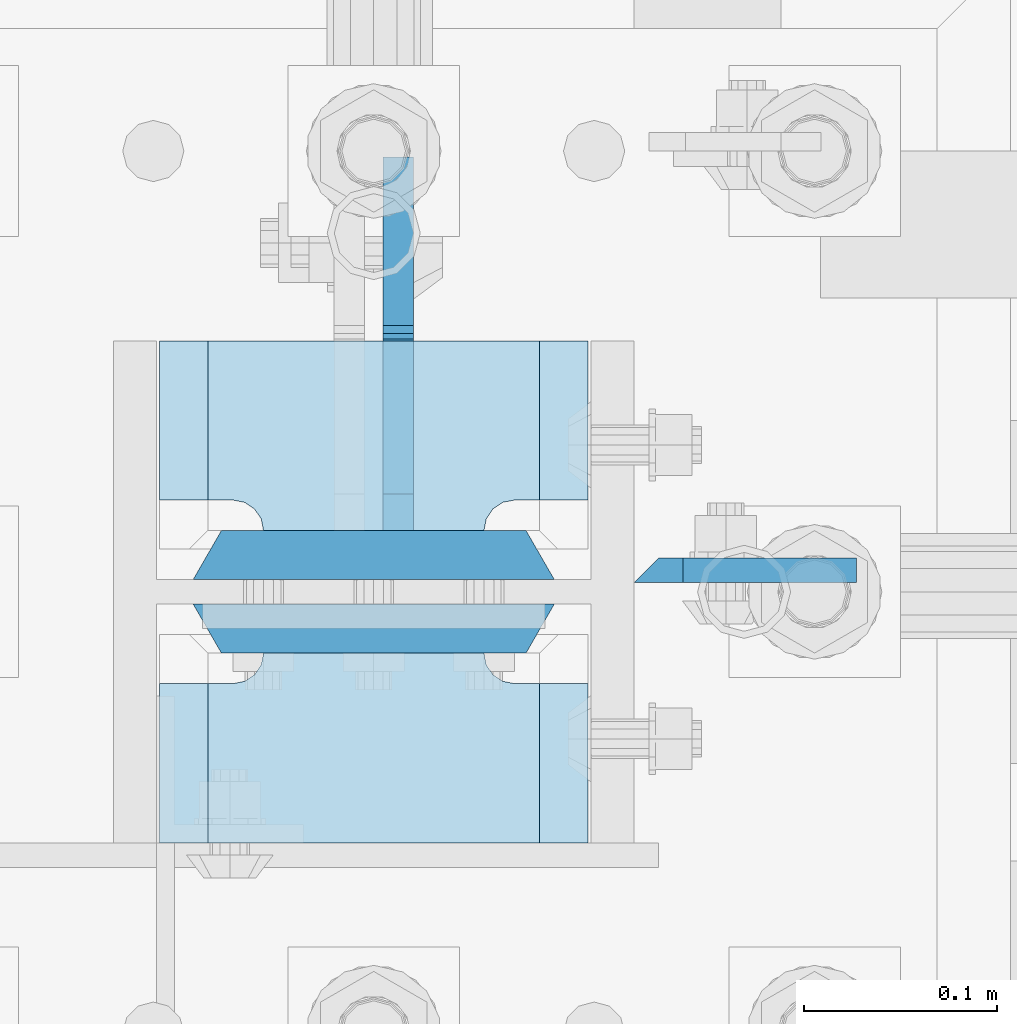
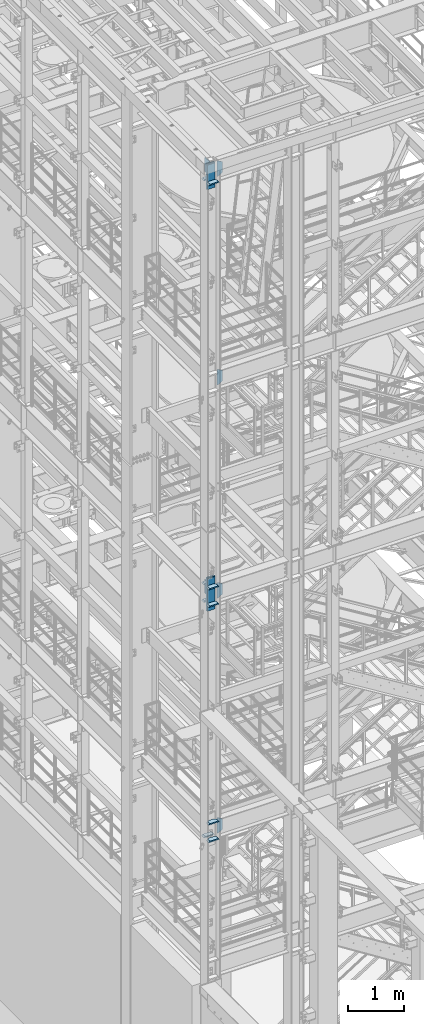
# One storey, part 1421 of 1876: 19 plates, 2 elements without a shape of their own.
"""IFC2X3 building model written with IfcOpenShell, lengths in millimetres."""

from ifc_helpers import new_model, si_unit, frame, origin_with_axes, place, context, subcontext, project, spatial, faceted_brep, material, type_object, element, aggregate, save


model = new_model("IFC2X3")

# Units and contexts
model_context = context("Model", 3, precision=1e-05, world=origin_with_axes())
body_context = subcontext(model_context, "Body", "Model", "MODEL_VIEW")
ifc_project = project(units=[si_unit("LENGTHUNIT", "METRE", prefix="MILLI"), si_unit("AREAUNIT", "SQUARE_METRE"), si_unit("VOLUMEUNIT", "CUBIC_METRE"), si_unit("MASSUNIT", "GRAM", prefix="KILO"), si_unit("TIMEUNIT", "SECOND"), si_unit("PLANEANGLEUNIT", "RADIAN"), si_unit("SOLIDANGLEUNIT", "STERADIAN"), si_unit("THERMODYNAMICTEMPERATUREUNIT", "DEGREE_CELSIUS"), si_unit("LUMINOUSINTENSITYUNIT", "LUMEN")], contexts=[model_context])

# Site, building, storey
site_placement = place(None, origin_with_axes())
site = spatial("IfcSite", under=ifc_project, at=site_placement, CompositionType="ELEMENT")
building_placement = place(site_placement, origin_with_axes())
building = spatial("IfcBuilding", under=site, at=building_placement, Name="Undefined", CompositionType="ELEMENT")
storey_placement = place(building_placement, origin_with_axes())
storey = spatial("IfcBuildingStorey", under=building, at=storey_placement, Name="Undefined", CompositionType="ELEMENT", Elevation=0.0)

# Assembly, plates
assembly_1_placement = place(storey_placement, origin_with_axes())
assembly_1 = element("IfcElementAssembly", 1, at=assembly_1_placement, inside=storey, Name="COLUMN", AssemblyPlace="NOTDEFINED", PredefinedType="RIGID_FRAME")
ifc_material_1 = material(Name="STEEL/A572-50")
plate_type_1 = type_object("IfcPlateType", PredefinedType="NOTDEFINED")
plate_1_placement = place(assembly_1_placement, frame((134.9375, -7100.88799991608, 17946.6875), z_axis=(1.0, 0.0, 0.0), x_axis=(0.0, 0.0, -1.0)))
plate_1 = element("IfcPlate", 2, at=plate_1_placement, type_object=plate_type_1, material=ifc_material_1, Name="PLATE", context=body_context, shape_type="Brep", body=[
    faceted_brep([(0.0, -6.35000000000036, 0.0), (-1.06936913171421e-12, 6.34999999999945, 12.699999332428), (336.549987792969, 6.35000000000036, 12.7), (336.549987792969, -6.35000000000036, 0.0), (336.550000000001, -6.35000000000036, 25.4000000000005), (336.549987792969, 6.35000000000036, 25.4000000000005), (284.53616791736, 6.35000000000036, 115.490600585938), (284.53616791736, -6.35000000000036, 115.490600307004), (52.0138320922852, -6.35000000000036, 115.490599060059), (52.0138320922852, 6.35000000000036, 115.490600585938), (0.0, 6.35000000000036, 25.4000000000005), (0.0, -6.35000000000036, 25.4000000000005)], [[[0, 1, 2, 3]], [[4, 5, 6, 7]], [[8, 9, 10, 11]], [[11, 10, 1, 0]], [[8, 11, 0, 3, 4, 7]], [[9, 8, 7, 6]], [[10, 9, 6, 5, 2, 1]], [[5, 4, 3, 2]]]),
])
plate_2_placement = place(assembly_1_placement, frame((134.9375, -7100.88799991608, 22518.6875), z_axis=(1.0, 0.0, 0.0), x_axis=(0.0, 0.0, -1.0)))
plate_2 = element("IfcPlate", 3, at=plate_2_placement, type_object=plate_type_1, material=ifc_material_1, Name="PLATE", context=body_context, shape_type="Brep", body=[
    faceted_brep([(0.0, -6.35000000000036, 0.0), (-1.06936913171421e-12, 6.34999999999945, 12.699999332428), (336.549987792969, 6.35000000000036, 12.7), (336.549987792969, -6.35000000000036, 0.0), (336.550000000001, -6.35000000000036, 25.4000000000005), (336.549987792969, 6.35000000000036, 25.4000000000005), (284.53616791736, 6.35000000000036, 115.490600585938), (284.53616791736, -6.35000000000036, 115.490600307004), (52.0138320922852, -6.35000000000036, 115.490599060059), (52.0138320922852, 6.35000000000036, 115.490600585938), (0.0, 6.35000000000036, 25.4000000000005), (0.0, -6.35000000000036, 25.4000000000005)], [[[0, 1, 2, 3]], [[4, 5, 6, 7]], [[8, 9, 10, 11]], [[11, 10, 1, 0]], [[8, 11, 0, 3, 4, 7]], [[9, 8, 7, 6]], [[10, 9, 6, 5, 2, 1]], [[5, 4, 3, 2]]]),
])

assembly_2_placement = place(storey_placement, origin_with_axes())
assembly_2 = element("IfcElementAssembly", 4, at=assembly_2_placement, inside=storey, Name="COLUMN", AssemblyPlace="NOTDEFINED", PredefinedType="RIGID_FRAME")
plate_3_placement = place(assembly_2_placement, frame((134.9375, -7100.88799991608, 13273.0875), z_axis=(1.0, 0.0, 0.0), x_axis=(0.0, 0.0, -1.0)))
plate_3 = element("IfcPlate", 5, at=plate_3_placement, type_object=plate_type_1, material=ifc_material_1, Name="PLATE", context=body_context, shape_type="Brep", body=[
    faceted_brep([(0.0, -6.35000000000036, 0.0), (-1.06936913171421e-12, 6.34999999999945, 12.699999332428), (336.549987792969, 6.35000000000036, 12.7), (336.549987792969, -6.35000000000036, 0.0), (336.550000000001, -6.35000000000036, 25.4000000000005), (336.549987792969, 6.35000000000036, 25.4000000000005), (284.53616791736, 6.35000000000036, 115.490600585938), (284.53616791736, -6.35000000000036, 115.490600307004), (52.0138320922852, -6.35000000000036, 115.490599060059), (52.0138320922852, 6.35000000000036, 115.490600585938), (0.0, 6.35000000000036, 25.4000000000005), (0.0, -6.35000000000036, 25.4000000000005)], [[[0, 1, 2, 3]], [[4, 5, 6, 7]], [[8, 9, 10, 11]], [[11, 10, 1, 0]], [[8, 11, 0, 3, 4, 7]], [[9, 8, 7, 6]], [[10, 9, 6, 5, 2, 1]], [[5, 4, 3, 2]]]),
])
plate_4_placement = place(assembly_2_placement, frame((134.9375, -7100.88799991608, 8116.8875), z_axis=(1.0, 0.0, 0.0), x_axis=(0.0, 0.0, -1.0)))
plate_4 = element("IfcPlate", 6, at=plate_4_placement, type_object=plate_type_1, material=ifc_material_1, Name="PLATE", context=body_context, shape_type="Brep", body=[
    faceted_brep([(0.0, -6.35000000000036, 0.0), (-1.06936913171421e-12, 6.34999999999945, 12.699999332428), (336.549987792969, 6.35000000000036, 12.7), (336.549987792969, -6.35000000000036, 0.0), (336.550000000001, -6.35000000000036, 25.4000000000005), (336.549987792969, 6.35000000000036, 25.4000000000005), (284.53616791736, 6.35000000000036, 115.490600585938), (284.53616791736, -6.35000000000036, 115.490600307004), (52.0138320922852, -6.35000000000036, 115.490599060059), (52.0138320922852, 6.35000000000036, 115.490600585938), (0.0, 6.35000000000036, 25.4000000000005), (0.0, -6.35000000000036, 25.4000000000005)], [[[0, 1, 2, 3]], [[4, 5, 6, 7]], [[8, 9, 10, 11]], [[11, 10, 1, 0]], [[8, 11, 0, 3, 4, 7]], [[9, 8, 7, 6]], [[10, 9, 6, 5, 2, 1]], [[5, 4, 3, 2]]]),
])

# Plate
plate_type_2 = type_object("IfcPlateType", PredefinedType="NOTDEFINED")
plate_5_placement = place(assembly_1_placement, frame((111.125, -7143.75, 22158.325012207), z_axis=(-1.0, 0.0, 0.0), x_axis=(0.0, -1.0, 0.0)))
plate_5 = element("IfcPlate", 7, at=plate_5_placement, type_object=plate_type_2, material=ifc_material_1, Name="PLATE", context=body_context, shape_type="Brep", body=[
    faceted_brep([(98.4250030517578, -12.7000000000007, 222.25), (98.4250030517578, 12.7000000000007, 197.150000002177), (15.875, 12.7000000000007, 197.150000002177), (15.875, -12.7000000000007, 222.25), (14.6665875786157, -12.7000000000007, 178.074902037082), (15.875, -12.7000000000007, 184.150001525879), (15.875, 12.7000000000007, 184.150001525879), (14.6665875786157, 12.7000000000007, 178.074902037082), (11.2253201513358, -12.7000000000007, 172.924681374541), (11.2253201513358, 12.7000000000007, 172.924681374541), (6.07509948879488, -12.7000000000007, 169.483413947261), (6.07509948879488, 12.7000000000007, 169.483413947261), (0.0, -12.7000000000007, 168.275001525879), (0.0, 12.7000000000007, 168.275001525879), (0.0, -12.7000000000007, 53.9749984741211), (0.0, 12.7000000000007, 53.9749984741211), (6.07509948879579, -12.7000000000007, 52.7665860527377), (6.07509948879579, 12.7000000000007, 52.7665860527377), (11.2253201513367, -12.7000000000007, 49.3253186254576), (11.2253201513367, 12.7000000000007, 49.3253186254576), (14.6665875786166, -12.7000000000007, 44.1750979629169), (14.6665875786166, 12.7000000000007, 44.1750979629169), (15.875, -12.7000000000007, 38.0999984741211), (15.875, 12.7000000000007, 38.0999984741211), (15.875, 12.7000000000007, 25.0999999978233), (15.875, -12.7000000000007, 0.0), (98.4250030517578, 12.7000000000007, 25.0999999978233), (98.4250030517578, -12.7000000000007, 0.0)], [[[0, 1, 2, 3]], [[4, 5, 6, 7]], [[8, 4, 7, 9]], [[10, 8, 9, 11]], [[12, 10, 11, 13]], [[14, 12, 13, 15]], [[16, 14, 15, 17]], [[18, 16, 17, 19]], [[20, 18, 19, 21]], [[22, 20, 21, 23]], [[22, 23, 24, 25]], [[26, 27, 25, 24]], [[5, 4, 8, 10, 12, 14, 16, 18, 20, 22, 25, 27, 0, 3]], [[6, 5, 3, 2]], [[26, 24, 23, 21, 19, 17, 15, 13, 11, 9, 7, 6, 2, 1]], [[27, 26, 1, 0]]]),
])

plate_6_placement = place(assembly_1_placement, frame((111.125, -6981.825, 22158.325012207), z_axis=(-1.0, 0.0, 0.0), x_axis=(0.0, -1.0, 0.0)))
plate_6 = element("IfcPlate", 8, at=plate_6_placement, type_object=plate_type_2, material=ifc_material_1, Name="PLATE", context=body_context, shape_type="Brep", body=[
    faceted_brep([(82.5500030517578, -12.7000000000007, 222.25), (82.5500030517578, 12.7000000000007, 197.150000002177), (0.0, 12.7000000000007, 197.150000002177), (0.0, -12.7000000000007, 222.25), (82.5500030517578, 12.7000000000007, 25.0999999978233), (82.5500030517578, -12.7000000000007, 0.0), (0.0, -12.6999999999998, 0.0), (0.0, 12.7000000000007, 25.0999999978233), (82.5500030517578, 12.7000000000007, 38.0999984741211), (82.5500030517578, -12.7000000000007, 38.0999984741211), (83.7584154731412, -12.7000000000007, 44.1750979629169), (83.7584154731412, 12.7000000000007, 44.1750979629169), (87.1996829004211, -12.7000000000007, 49.3253186254576), (87.1996829004211, 12.7000000000007, 49.3253186254576), (92.349903562962, -12.7000000000007, 52.7665860527377), (92.349903562962, 12.7000000000007, 52.7665860527377), (98.4250030517578, -12.7000000000007, 53.9749984741211), (98.4250030517578, 12.7000000000007, 53.9749984741211), (98.4250030517578, -12.7000000000007, 168.275001525879), (98.4250030517578, 12.7000000000007, 168.275001525879), (92.349903562962, -12.7000000000007, 169.483413947262), (92.349903562962, 12.7000000000007, 169.483413947262), (87.1996829004211, -12.7000000000007, 172.924681374543), (87.1996829004211, 12.7000000000007, 172.924681374543), (83.7584154731412, -12.7000000000007, 178.074902037083), (83.7584154731412, 12.7000000000007, 178.074902037083), (82.5500030517578, -12.7000000000007, 184.150001525879), (82.5500030517578, 12.7000000000007, 184.150001525879)], [[[0, 1, 2, 3]], [[4, 5, 6, 7]], [[8, 9, 5, 4]], [[10, 9, 8, 11]], [[12, 10, 11, 13]], [[14, 12, 13, 15]], [[16, 14, 15, 17]], [[18, 16, 17, 19]], [[20, 18, 19, 21]], [[22, 20, 21, 23]], [[24, 22, 23, 25]], [[26, 24, 25, 27]], [[6, 5, 9, 10, 12, 14, 16, 18, 20, 22, 24, 26, 0, 3]], [[7, 6, 3, 2]], [[27, 25, 23, 21, 19, 17, 15, 13, 11, 8, 4, 7, 2, 1]], [[26, 27, 1, 0]]]),
])

plate_7_placement = place(assembly_2_placement, frame((111.125, -7143.75, 12912.725012207), z_axis=(-1.0, 0.0, 0.0), x_axis=(0.0, -1.0, 0.0)))
plate_7 = element("IfcPlate", 9, at=plate_7_placement, type_object=plate_type_2, material=ifc_material_1, Name="PLATE", context=body_context, shape_type="Brep", body=[
    faceted_brep([(98.4250030517578, -12.7000000000007, 222.25), (98.4250030517578, 12.7000000000007, 197.150000002177), (15.875, 12.7000000000007, 197.150000002177), (15.875, -12.7000000000007, 222.25), (14.6665875786157, -12.7000000000007, 178.074902037082), (15.875, -12.7000000000007, 184.150001525879), (15.875, 12.7000000000007, 184.150001525879), (14.6665875786157, 12.7000000000007, 178.074902037082), (11.2253201513358, -12.7000000000007, 172.924681374541), (11.2253201513358, 12.7000000000007, 172.924681374541), (6.07509948879488, -12.7000000000007, 169.483413947261), (6.07509948879488, 12.7000000000007, 169.483413947261), (0.0, -12.7000000000007, 168.275001525879), (0.0, 12.7000000000007, 168.275001525879), (0.0, -12.7000000000007, 53.9749984741211), (0.0, 12.7000000000007, 53.9749984741211), (6.07509948879579, -12.7000000000007, 52.7665860527377), (6.07509948879579, 12.7000000000007, 52.7665860527377), (11.2253201513367, -12.7000000000007, 49.3253186254576), (11.2253201513367, 12.7000000000007, 49.3253186254576), (14.6665875786166, -12.7000000000007, 44.1750979629169), (14.6665875786166, 12.7000000000007, 44.1750979629169), (15.875, -12.7000000000007, 38.0999984741211), (15.875, 12.7000000000007, 38.0999984741211), (15.875, 12.7000000000007, 25.0999999978233), (15.875, -12.7000000000007, 0.0), (98.4250030517578, 12.7000000000007, 25.0999999978233), (98.4250030517578, -12.7000000000007, 0.0)], [[[0, 1, 2, 3]], [[4, 5, 6, 7]], [[8, 4, 7, 9]], [[10, 8, 9, 11]], [[12, 10, 11, 13]], [[14, 12, 13, 15]], [[16, 14, 15, 17]], [[18, 16, 17, 19]], [[20, 18, 19, 21]], [[22, 20, 21, 23]], [[22, 23, 24, 25]], [[26, 27, 25, 24]], [[5, 4, 8, 10, 12, 14, 16, 18, 20, 22, 25, 27, 0, 3]], [[6, 5, 3, 2]], [[26, 24, 23, 21, 19, 17, 15, 13, 11, 9, 7, 6, 2, 1]], [[27, 26, 1, 0]]]),
])

plate_8_placement = place(assembly_2_placement, frame((111.125, -7143.75, 13296.9), z_axis=(-1.0, 0.0, 0.0), x_axis=(0.0, -1.0, 0.0)))
plate_8 = element("IfcPlate", 10, at=plate_8_placement, type_object=plate_type_2, material=ifc_material_1, Name="PLATE", context=body_context, shape_type="Brep", body=[
    faceted_brep([(98.4250030517578, -12.7000000000007, 222.25), (98.4250030517578, 12.7000000000007, 197.150000002177), (15.875, 12.7000000000007, 197.150000002177), (15.875, -12.7000000000007, 222.25), (14.6665875786157, -12.7000000000007, 178.074902037082), (15.875, -12.7000000000007, 184.150001525879), (15.875, 12.7000000000007, 184.150001525879), (14.6665875786157, 12.7000000000007, 178.074902037082), (11.2253201513358, -12.7000000000007, 172.924681374541), (11.2253201513358, 12.7000000000007, 172.924681374541), (6.07509948879488, -12.7000000000007, 169.483413947261), (6.07509948879488, 12.7000000000007, 169.483413947261), (0.0, -12.7000000000007, 168.275001525879), (0.0, 12.7000000000007, 168.275001525879), (0.0, -12.7000000000007, 53.9749984741211), (0.0, 12.7000000000007, 53.9749984741211), (6.07509948879579, -12.7000000000007, 52.7665860527377), (6.07509948879579, 12.7000000000007, 52.7665860527377), (11.2253201513367, -12.7000000000007, 49.3253186254576), (11.2253201513367, 12.7000000000007, 49.3253186254576), (14.6665875786166, -12.7000000000007, 44.1750979629169), (14.6665875786166, 12.7000000000007, 44.1750979629169), (15.875, -12.7000000000007, 38.0999984741211), (15.875, 12.7000000000007, 38.0999984741211), (15.875, 12.7000000000007, 25.0999999978233), (15.875, -12.7000000000007, 0.0), (98.4250030517578, 12.7000000000007, 25.0999999978233), (98.4250030517578, -12.7000000000007, 0.0)], [[[0, 1, 2, 3]], [[4, 5, 6, 7]], [[8, 4, 7, 9]], [[10, 8, 9, 11]], [[12, 10, 11, 13]], [[14, 12, 13, 15]], [[16, 14, 15, 17]], [[18, 16, 17, 19]], [[20, 18, 19, 21]], [[22, 20, 21, 23]], [[22, 23, 24, 25]], [[26, 27, 25, 24]], [[5, 4, 8, 10, 12, 14, 16, 18, 20, 22, 25, 27, 0, 3]], [[6, 5, 3, 2]], [[26, 24, 23, 21, 19, 17, 15, 13, 11, 9, 7, 6, 2, 1]], [[27, 26, 1, 0]]]),
])

plate_9_placement = place(assembly_2_placement, frame((111.125, -6981.825, 12912.725012207), z_axis=(-1.0, 0.0, 0.0), x_axis=(0.0, -1.0, 0.0)))
plate_9 = element("IfcPlate", 11, at=plate_9_placement, type_object=plate_type_2, material=ifc_material_1, Name="PLATE", context=body_context, shape_type="Brep", body=[
    faceted_brep([(82.5500030517578, -12.7000000000007, 222.25), (82.5500030517578, 12.7000000000007, 197.150000002177), (0.0, 12.7000000000007, 197.150000002177), (0.0, -12.7000000000007, 222.25), (82.5500030517578, 12.7000000000007, 25.0999999978233), (82.5500030517578, -12.7000000000007, 0.0), (0.0, -12.6999999999998, 0.0), (0.0, 12.7000000000007, 25.0999999978233), (82.5500030517578, 12.7000000000007, 38.0999984741211), (82.5500030517578, -12.7000000000007, 38.0999984741211), (83.7584154731412, -12.7000000000007, 44.1750979629169), (83.7584154731412, 12.7000000000007, 44.1750979629169), (87.1996829004211, -12.7000000000007, 49.3253186254576), (87.1996829004211, 12.7000000000007, 49.3253186254576), (92.349903562962, -12.7000000000007, 52.7665860527377), (92.349903562962, 12.7000000000007, 52.7665860527377), (98.4250030517578, -12.7000000000007, 53.9749984741211), (98.4250030517578, 12.7000000000007, 53.9749984741211), (98.4250030517578, -12.7000000000007, 168.275001525879), (98.4250030517578, 12.7000000000007, 168.275001525879), (92.349903562962, -12.7000000000007, 169.483413947262), (92.349903562962, 12.7000000000007, 169.483413947262), (87.1996829004211, -12.7000000000007, 172.924681374543), (87.1996829004211, 12.7000000000007, 172.924681374543), (83.7584154731412, -12.7000000000007, 178.074902037083), (83.7584154731412, 12.7000000000007, 178.074902037083), (82.5500030517578, -12.7000000000007, 184.150001525879), (82.5500030517578, 12.7000000000007, 184.150001525879)], [[[0, 1, 2, 3]], [[4, 5, 6, 7]], [[8, 9, 5, 4]], [[10, 9, 8, 11]], [[12, 10, 11, 13]], [[14, 12, 13, 15]], [[16, 14, 15, 17]], [[18, 16, 17, 19]], [[20, 18, 19, 21]], [[22, 20, 21, 23]], [[24, 22, 23, 25]], [[26, 24, 25, 27]], [[6, 5, 9, 10, 12, 14, 16, 18, 20, 22, 24, 26, 0, 3]], [[7, 6, 3, 2]], [[27, 25, 23, 21, 19, 17, 15, 13, 11, 8, 4, 7, 2, 1]], [[26, 27, 1, 0]]]),
])

plate_10_placement = place(assembly_2_placement, frame((111.125, -6981.825, 13296.9), z_axis=(-1.0, 0.0, 0.0), x_axis=(0.0, -1.0, 0.0)))
plate_10 = element("IfcPlate", 12, at=plate_10_placement, type_object=plate_type_2, material=ifc_material_1, Name="PLATE", context=body_context, shape_type="Brep", body=[
    faceted_brep([(82.5500030517578, -12.7000000000007, 222.25), (82.5500030517578, 12.7000000000007, 197.150000002177), (0.0, 12.7000000000007, 197.150000002177), (0.0, -12.7000000000007, 222.25), (82.5500030517578, 12.7000000000007, 25.0999999978233), (82.5500030517578, -12.7000000000007, 0.0), (0.0, -12.6999999999998, 0.0), (0.0, 12.7000000000007, 25.0999999978233), (82.5500030517578, 12.7000000000007, 38.0999984741211), (82.5500030517578, -12.7000000000007, 38.0999984741211), (83.7584154731412, -12.7000000000007, 44.1750979629169), (83.7584154731412, 12.7000000000007, 44.1750979629169), (87.1996829004211, -12.7000000000007, 49.3253186254576), (87.1996829004211, 12.7000000000007, 49.3253186254576), (92.349903562962, -12.7000000000007, 52.7665860527377), (92.349903562962, 12.7000000000007, 52.7665860527377), (98.4250030517578, -12.7000000000007, 53.9749984741211), (98.4250030517578, 12.7000000000007, 53.9749984741211), (98.4250030517578, -12.7000000000007, 168.275001525879), (98.4250030517578, 12.7000000000007, 168.275001525879), (92.349903562962, -12.7000000000007, 169.483413947262), (92.349903562962, 12.7000000000007, 169.483413947262), (87.1996829004211, -12.7000000000007, 172.924681374543), (87.1996829004211, 12.7000000000007, 172.924681374543), (83.7584154731412, -12.7000000000007, 178.074902037083), (83.7584154731412, 12.7000000000007, 178.074902037083), (82.5500030517578, -12.7000000000007, 184.150001525879), (82.5500030517578, 12.7000000000007, 184.150001525879)], [[[0, 1, 2, 3]], [[4, 5, 6, 7]], [[8, 9, 5, 4]], [[10, 9, 8, 11]], [[12, 10, 11, 13]], [[14, 12, 13, 15]], [[16, 14, 15, 17]], [[18, 16, 17, 19]], [[20, 18, 19, 21]], [[22, 20, 21, 23]], [[24, 22, 23, 25]], [[26, 24, 25, 27]], [[6, 5, 9, 10, 12, 14, 16, 18, 20, 22, 24, 26, 0, 3]], [[7, 6, 3, 2]], [[27, 25, 23, 21, 19, 17, 15, 13, 11, 8, 4, 7, 2, 1]], [[26, 27, 1, 0]]]),
])

plate_11_placement = place(assembly_2_placement, frame((111.125, -7143.75, 7756.52501220703), z_axis=(-1.0, 0.0, 0.0), x_axis=(0.0, -1.0, 0.0)))
plate_11 = element("IfcPlate", 13, at=plate_11_placement, type_object=plate_type_2, material=ifc_material_1, Name="PLATE", context=body_context, shape_type="Brep", body=[
    faceted_brep([(98.4250030517578, -12.7000000000007, 222.25), (98.4250030517578, 12.7000000000007, 197.150000002177), (15.875, 12.7000000000007, 197.150000002177), (15.875, -12.7000000000007, 222.25), (14.6665875786157, -12.7000000000007, 178.074902037082), (15.875, -12.7000000000007, 184.150001525879), (15.875, 12.7000000000007, 184.150001525879), (14.6665875786157, 12.7000000000007, 178.074902037082), (11.2253201513358, -12.7000000000007, 172.924681374541), (11.2253201513358, 12.7000000000007, 172.924681374541), (6.07509948879488, -12.7000000000007, 169.483413947261), (6.07509948879488, 12.7000000000007, 169.483413947261), (0.0, -12.7000000000007, 168.275001525879), (0.0, 12.7000000000007, 168.275001525879), (0.0, -12.7000000000007, 53.9749984741211), (0.0, 12.7000000000007, 53.9749984741211), (6.07509948879579, -12.7000000000007, 52.7665860527377), (6.07509948879579, 12.7000000000007, 52.7665860527377), (11.2253201513367, -12.7000000000007, 49.3253186254576), (11.2253201513367, 12.7000000000007, 49.3253186254576), (14.6665875786166, -12.7000000000007, 44.1750979629169), (14.6665875786166, 12.7000000000007, 44.1750979629169), (15.875, -12.7000000000007, 38.0999984741211), (15.875, 12.7000000000007, 38.0999984741211), (15.875, 12.7000000000007, 25.0999999978233), (15.875, -12.7000000000007, 0.0), (98.4250030517578, 12.7000000000007, 25.0999999978233), (98.4250030517578, -12.7000000000007, 0.0)], [[[0, 1, 2, 3]], [[4, 5, 6, 7]], [[8, 4, 7, 9]], [[10, 8, 9, 11]], [[12, 10, 11, 13]], [[14, 12, 13, 15]], [[16, 14, 15, 17]], [[18, 16, 17, 19]], [[20, 18, 19, 21]], [[22, 20, 21, 23]], [[22, 23, 24, 25]], [[26, 27, 25, 24]], [[5, 4, 8, 10, 12, 14, 16, 18, 20, 22, 25, 27, 0, 3]], [[6, 5, 3, 2]], [[26, 24, 23, 21, 19, 17, 15, 13, 11, 9, 7, 6, 2, 1]], [[27, 26, 1, 0]]]),
])

plate_12_placement = place(assembly_2_placement, frame((111.125, -7143.75, 8140.7), z_axis=(-1.0, 0.0, 0.0), x_axis=(0.0, -1.0, 0.0)))
plate_12 = element("IfcPlate", 14, at=plate_12_placement, type_object=plate_type_2, material=ifc_material_1, Name="PLATE", context=body_context, shape_type="Brep", body=[
    faceted_brep([(98.4250030517578, -12.7000000000007, 222.25), (98.4250030517578, 12.7000000000007, 197.150000002177), (15.875, 12.7000000000007, 197.150000002177), (15.875, -12.7000000000007, 222.25), (14.6665875786157, -12.7000000000007, 178.074902037082), (15.875, -12.7000000000007, 184.150001525879), (15.875, 12.7000000000007, 184.150001525879), (14.6665875786157, 12.7000000000007, 178.074902037082), (11.2253201513358, -12.7000000000007, 172.924681374541), (11.2253201513358, 12.7000000000007, 172.924681374541), (6.07509948879488, -12.7000000000007, 169.483413947261), (6.07509948879488, 12.7000000000007, 169.483413947261), (0.0, -12.7000000000007, 168.275001525879), (0.0, 12.7000000000007, 168.275001525879), (0.0, -12.7000000000007, 53.9749984741211), (0.0, 12.7000000000007, 53.9749984741211), (6.07509948879579, -12.7000000000007, 52.7665860527377), (6.07509948879579, 12.7000000000007, 52.7665860527377), (11.2253201513367, -12.7000000000007, 49.3253186254576), (11.2253201513367, 12.7000000000007, 49.3253186254576), (14.6665875786166, -12.7000000000007, 44.1750979629169), (14.6665875786166, 12.7000000000007, 44.1750979629169), (15.875, -12.7000000000007, 38.0999984741211), (15.875, 12.7000000000007, 38.0999984741211), (15.875, 12.7000000000007, 25.0999999978233), (15.875, -12.7000000000007, 0.0), (98.4250030517578, 12.7000000000007, 25.0999999978233), (98.4250030517578, -12.7000000000007, 0.0)], [[[0, 1, 2, 3]], [[4, 5, 6, 7]], [[8, 4, 7, 9]], [[10, 8, 9, 11]], [[12, 10, 11, 13]], [[14, 12, 13, 15]], [[16, 14, 15, 17]], [[18, 16, 17, 19]], [[20, 18, 19, 21]], [[22, 20, 21, 23]], [[22, 23, 24, 25]], [[26, 27, 25, 24]], [[5, 4, 8, 10, 12, 14, 16, 18, 20, 22, 25, 27, 0, 3]], [[6, 5, 3, 2]], [[26, 24, 23, 21, 19, 17, 15, 13, 11, 9, 7, 6, 2, 1]], [[27, 26, 1, 0]]]),
])

plate_13_placement = place(assembly_2_placement, frame((111.125, -6981.825, 7756.52501220703), z_axis=(-1.0, 0.0, 0.0), x_axis=(0.0, -1.0, 0.0)))
plate_13 = element("IfcPlate", 15, at=plate_13_placement, type_object=plate_type_2, material=ifc_material_1, Name="PLATE", context=body_context, shape_type="Brep", body=[
    faceted_brep([(82.5500030517578, -12.7000000000007, 222.25), (82.5500030517578, 12.7000000000007, 197.150000002177), (0.0, 12.7000000000007, 197.150000002177), (0.0, -12.7000000000007, 222.25), (82.5500030517578, 12.7000000000007, 25.0999999978233), (82.5500030517578, -12.7000000000007, 0.0), (0.0, -12.6999999999998, 0.0), (0.0, 12.7000000000007, 25.0999999978233), (82.5500030517578, 12.7000000000007, 38.0999984741211), (82.5500030517578, -12.7000000000007, 38.0999984741211), (83.7584154731412, -12.7000000000007, 44.1750979629169), (83.7584154731412, 12.7000000000007, 44.1750979629169), (87.1996829004211, -12.7000000000007, 49.3253186254576), (87.1996829004211, 12.7000000000007, 49.3253186254576), (92.349903562962, -12.7000000000007, 52.7665860527377), (92.349903562962, 12.7000000000007, 52.7665860527377), (98.4250030517578, -12.7000000000007, 53.9749984741211), (98.4250030517578, 12.7000000000007, 53.9749984741211), (98.4250030517578, -12.7000000000007, 168.275001525879), (98.4250030517578, 12.7000000000007, 168.275001525879), (92.349903562962, -12.7000000000007, 169.483413947262), (92.349903562962, 12.7000000000007, 169.483413947262), (87.1996829004211, -12.7000000000007, 172.924681374543), (87.1996829004211, 12.7000000000007, 172.924681374543), (83.7584154731412, -12.7000000000007, 178.074902037083), (83.7584154731412, 12.7000000000007, 178.074902037083), (82.5500030517578, -12.7000000000007, 184.150001525879), (82.5500030517578, 12.7000000000007, 184.150001525879)], [[[0, 1, 2, 3]], [[4, 5, 6, 7]], [[8, 9, 5, 4]], [[10, 9, 8, 11]], [[12, 10, 11, 13]], [[14, 12, 13, 15]], [[16, 14, 15, 17]], [[18, 16, 17, 19]], [[20, 18, 19, 21]], [[22, 20, 21, 23]], [[24, 22, 23, 25]], [[26, 24, 25, 27]], [[6, 5, 9, 10, 12, 14, 16, 18, 20, 22, 24, 26, 0, 3]], [[7, 6, 3, 2]], [[27, 25, 23, 21, 19, 17, 15, 13, 11, 8, 4, 7, 2, 1]], [[26, 27, 1, 0]]]),
])

ifc_material_2 = material(Name="STEEL/A572-GR.50")
plate_type_3 = type_object("IfcPlateType", PredefinedType="NOTDEFINED")
plate_14_placement = place(assembly_1_placement, frame((-93.6625, -7092.95, 22529.8), z_axis=(1.0, 0.0, 0.0), x_axis=(0.0, 0.0, -1.0)))
plate_14 = element("IfcPlate", 16, at=plate_14_placement, type_object=plate_type_3, material=ifc_material_2, Name="PLATE", context=body_context, shape_type="Brep", body=[
    faceted_brep([(0.0, 12.6999999999998, 172.66030316161), (0.0, -12.6999999999998, 187.324996948242), (536.575012207031, -12.6999999999998, 187.324996948242), (536.575012207031, 12.6999999999998, 172.66030316161), (536.575012207031, 12.6999999999998, 14.6646968383725), (0.0, 12.6999999999998, 14.6646968383725), (0.0, -12.6999999999998, 0.0), (536.575012207031, -12.6999999999998, 0.0)], [[[0, 1, 2, 3]], [[0, 3, 4, 5]], [[1, 0, 5, 6]], [[2, 1, 6, 7]], [[3, 2, 7, 4]], [[6, 5, 4, 7]]]),
])

plate_15_placement = place(assembly_1_placement, frame((-93.6625, -7131.05, 22529.8), z_axis=(1.0, 0.0, 0.0), x_axis=(0.0, 0.0, -1.0)))
plate_15 = element("IfcPlate", 17, at=plate_15_placement, type_object=plate_type_3, material=ifc_material_2, Name="PLATE", context=body_context, shape_type="Brep", body=[
    faceted_brep([(0.0, -12.6999999999998, 172.660303166218), (536.575012207031, -12.6999999999998, 172.660303166218), (536.575012207031, 12.6999999999998, 187.324996948242), (0.0, 12.6999999999998, 187.324996948242), (536.575012207031, -12.6999999999998, 14.6646968337648), (536.575012207031, 12.6999999999998, 0.0), (0.0, 12.6999999999998, 0.0), (0.0, -12.6999999999998, 14.6646968337648)], [[[0, 1, 2, 3]], [[2, 1, 4, 5]], [[3, 2, 5, 6]], [[0, 3, 6, 7]], [[1, 0, 7, 4]], [[6, 5, 4, 7]]]),
])

plate_16_placement = place(assembly_2_placement, frame((-93.6625, -7131.05, 13462.0), z_axis=(1.0, 0.0, 0.0), x_axis=(0.0, 0.0, -1.0)))
plate_16 = element("IfcPlate", 18, at=plate_16_placement, type_object=plate_type_3, material=ifc_material_2, Name="PLATE", context=body_context, shape_type="Brep", body=[
    faceted_brep([(0.0, -12.6999999999998, 172.660303166218), (714.375, -12.6999999999998, 172.660303166232), (714.375, 12.6999999999998, 187.324996948242), (0.0, 12.6999999999998, 187.324996948242), (714.375, -12.6999999999998, 14.6646968337647), (714.375, 12.6999999999998, 0.0), (0.0, 12.6999999999998, 0.0), (0.0, -12.6999999999998, 14.6646968337648)], [[[0, 1, 2, 3]], [[2, 1, 4, 5]], [[3, 2, 5, 6]], [[0, 3, 6, 7]], [[1, 0, 7, 4]], [[6, 5, 4, 7]]]),
])

plate_17_placement = place(assembly_2_placement, frame((-93.6625, -7092.95, 13462.0), z_axis=(1.0, 0.0, 0.0), x_axis=(0.0, 0.0, -1.0)))
plate_17 = element("IfcPlate", 19, at=plate_17_placement, type_object=plate_type_3, material=ifc_material_2, Name="PLATE", context=body_context, shape_type="Brep", body=[
    faceted_brep([(0.0, 12.6999999999998, 172.66030316161), (0.0, -12.6999999999998, 187.324996948242), (714.375, -12.6999999999998, 187.324996948242), (714.375, 12.6999999999998, 172.660303161603), (714.375, 12.6999999999998, 14.6646968384017), (0.0, 12.6999999999998, 14.6646968383725), (0.0, -12.6999999999998, 0.0), (714.375, -12.6999999999998, 0.0)], [[[0, 1, 2, 3]], [[0, 3, 4, 5]], [[1, 0, 5, 6]], [[2, 1, 6, 7]], [[3, 2, 7, 4]], [[6, 5, 4, 7]]]),
])

plate_type_4 = type_object("IfcPlateType", PredefinedType="NOTDEFINED")
plate_18_placement = place(assembly_1_placement, frame((12.6995000839233, -7080.25, 22529.8), z_axis=(0.0, 1.0, 0.0), x_axis=(0.0, 0.0, -1.0)))
plate_18 = element("IfcPlate", 20, at=plate_18_placement, type_object=plate_type_4, material=ifc_material_1, Name="PLATE", context=body_context, shape_type="Brep", body=[
    faceted_brep([(317.499987030027, -7.9375, 193.675002687786), (317.499987030027, -7.9375, 111.124999809264), (317.499987030027, 7.9375, 111.124999809264), (317.499987030027, 7.9375, 193.675003051758), (318.466716952618, -7.9375, 106.264920291219), (318.466716952618, 7.9375, 106.264920291219), (321.219730853096, -7.9375, 102.144743823065), (321.219730853096, 7.9375, 102.144743823065), (325.339907321249, -7.9375, 99.3917299225868), (325.339907321249, 7.9375, 99.3917299225868), (330.199986839292, -7.9375, 98.4249999999993), (330.199986839292, 7.9375, 98.4249999999993), (358.774999999998, -7.9375, 98.4249999999993), (358.774993896484, 7.9375, 98.4249999999993), (12.7000000839216, -7.9375, 193.674999999999), (12.7000000839216, 7.9375, 193.675003051758), (12.7000000839216, 7.9375, 111.124999809264), (12.7000000839216, -7.9375, 111.124999809264), (11.7332701613341, 7.9375, 106.264920291219), (11.7332701613341, -7.9375, 106.264920291219), (8.98025626085655, 7.9375, 102.144743823065), (8.98025626085655, -7.9375, 102.144743823065), (4.86007979270289, 7.9375, 99.3917299225868), (4.86007979270289, -7.9375, 99.3917299225868), (0.0, 7.9375, 98.4249999999993), (0.0, -7.9375, 98.4249999999993), (0.0, 7.9375, 19.0499992370605), (0.0, -7.9375, 19.0499992370605), (19.0499992370605, -7.9375, 0.0), (19.0499992370605, 7.9375, 0.0), (339.724994659424, -7.9375, 0.0), (339.724994659424, 7.9375, 0.0), (358.774993896484, -7.9375, 19.0499992370605), (358.774993896484, 7.9375, 19.0499992370605)], [[[0, 1, 2, 3]], [[4, 5, 2, 1]], [[6, 7, 5, 4]], [[8, 9, 7, 6]], [[10, 11, 9, 8]], [[12, 13, 11, 10]], [[14, 15, 16, 17]], [[17, 16, 18, 19]], [[19, 18, 20, 21]], [[21, 20, 22, 23]], [[23, 22, 24, 25]], [[26, 27, 25, 24]], [[28, 27, 26, 29]], [[30, 28, 29, 31]], [[32, 30, 31, 33]], [[8, 6, 4, 1, 0, 14, 17, 19, 21, 23, 25, 27, 28, 30, 32, 12, 10]], [[15, 14, 0, 3]], [[33, 31, 29, 26, 24, 22, 20, 18, 16, 15, 3, 2, 5, 7, 9, 11, 13]], [[32, 33, 13, 12]]]),
])

aggregate(assembly_1, [plate_1, plate_2, plate_5, plate_6, plate_18, plate_14, plate_15])

plate_19_placement = place(assembly_2_placement, frame((12.6995000839233, -7080.25, 13284.2), z_axis=(0.0, 1.0, 0.0), x_axis=(0.0, 0.0, -1.0)))
plate_19 = element("IfcPlate", 21, at=plate_19_placement, type_object=plate_type_4, material=ifc_material_1, Name="PLATE", context=body_context, shape_type="Brep", body=[
    faceted_brep([(317.499987030027, -7.9375, 193.675002687786), (317.499987030027, -7.9375, 111.124999809264), (317.499987030027, 7.9375, 111.124999809264), (317.499987030027, 7.9375, 193.675003051758), (318.466716952618, -7.9375, 106.264920291219), (318.466716952618, 7.9375, 106.264920291219), (321.219730853096, -7.9375, 102.144743823065), (321.219730853096, 7.9375, 102.144743823065), (325.339907321249, -7.9375, 99.3917299225868), (325.339907321249, 7.9375, 99.3917299225868), (330.199986839292, -7.9375, 98.4249999999993), (330.199986839292, 7.9375, 98.4249999999993), (358.774999999998, -7.9375, 98.4249999999993), (358.774993896484, 7.9375, 98.4249999999993), (12.7000000839216, -7.9375, 193.674999999999), (12.7000000839216, 7.9375, 193.675003051758), (12.7000000839216, 7.9375, 111.124999809264), (12.7000000839216, -7.9375, 111.124999809264), (11.7332701613341, 7.9375, 106.264920291219), (11.7332701613341, -7.9375, 106.264920291219), (8.98025626085655, 7.9375, 102.144743823065), (8.98025626085655, -7.9375, 102.144743823065), (4.86007979270289, 7.9375, 99.3917299225868), (4.86007979270289, -7.9375, 99.3917299225868), (0.0, 7.9375, 98.4249999999993), (0.0, -7.9375, 98.4249999999993), (0.0, 7.9375, 19.0499992370605), (0.0, -7.9375, 19.0499992370605), (19.0499992370605, -7.9375, 0.0), (19.0499992370605, 7.9375, 0.0), (339.724994659424, -7.9375, 0.0), (339.724994659424, 7.9375, 0.0), (358.774993896484, -7.9375, 19.0499992370605), (358.774993896484, 7.9375, 19.0499992370605)], [[[0, 1, 2, 3]], [[4, 5, 2, 1]], [[6, 7, 5, 4]], [[8, 9, 7, 6]], [[10, 11, 9, 8]], [[12, 13, 11, 10]], [[14, 15, 16, 17]], [[17, 16, 18, 19]], [[19, 18, 20, 21]], [[21, 20, 22, 23]], [[23, 22, 24, 25]], [[26, 27, 25, 24]], [[28, 27, 26, 29]], [[30, 28, 29, 31]], [[32, 30, 31, 33]], [[8, 6, 4, 1, 0, 14, 17, 19, 21, 23, 25, 27, 28, 30, 32, 12, 10]], [[15, 14, 0, 3]], [[33, 31, 29, 26, 24, 22, 20, 18, 16, 15, 3, 2, 5, 7, 9, 11, 13]], [[32, 33, 13, 12]]]),
])

aggregate(assembly_2, [plate_7, plate_8, plate_9, plate_10, plate_16, plate_17, plate_19, plate_3, plate_4, plate_11, plate_12, plate_13])

save(model, "model.ifc")
